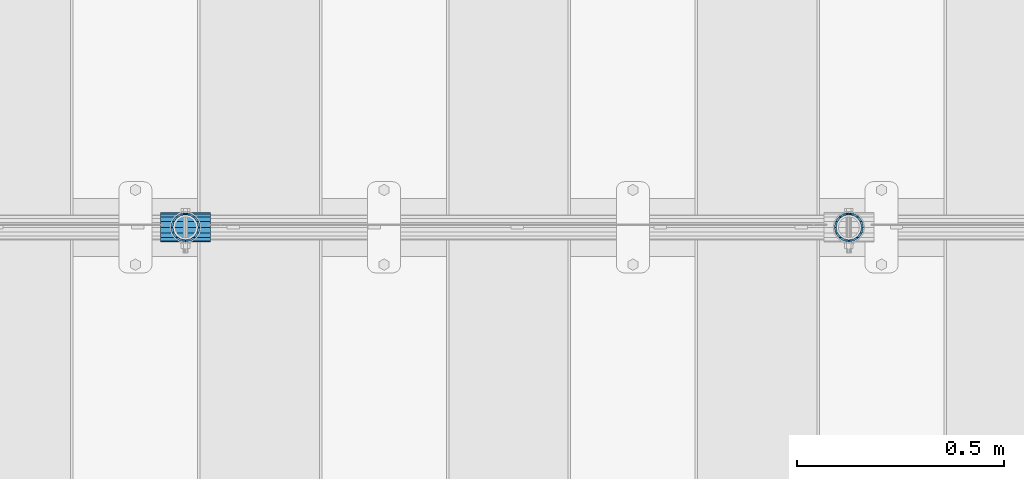
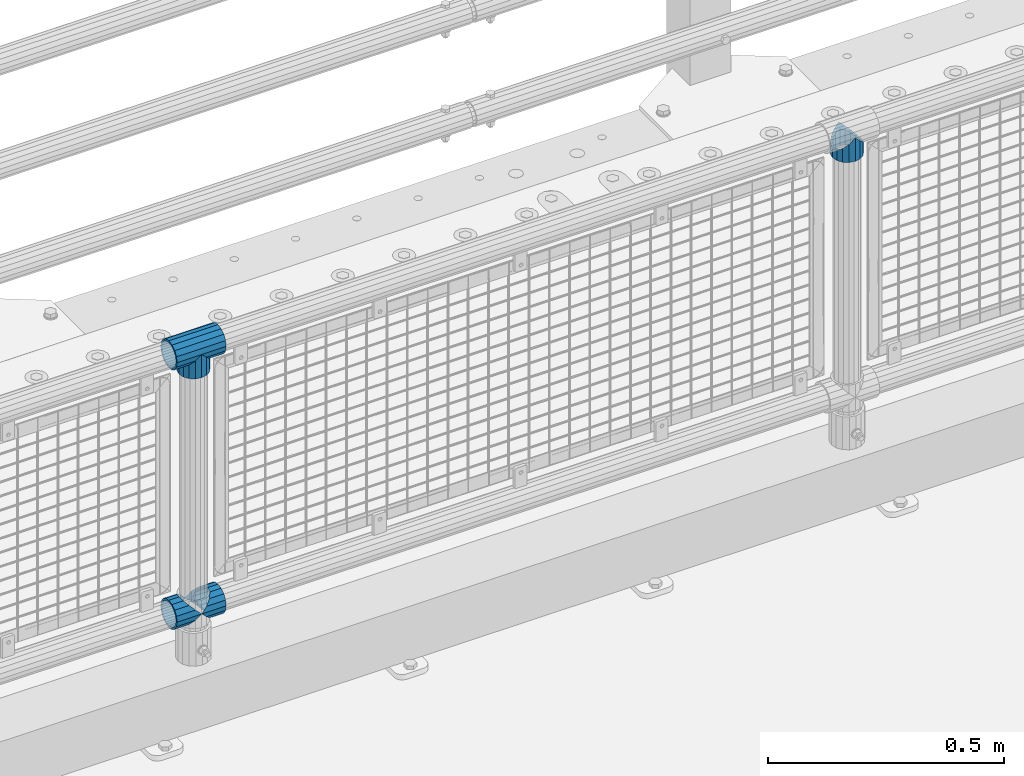
# One storey, part 122 of 208: 5 beams.
"""IFC2X3 building model written with IfcOpenShell, lengths in millimetres."""

from ifc_helpers import new_model, si_unit, frame, origin_with_axes, place, context, subcontext, project, spatial, faceted_brep, material, type_object, element, save


model = new_model("IFC2X3")

# Units and contexts
model_context = context("Model", 3, precision=1e-05, world=origin_with_axes())
body_context = subcontext(model_context, "Body", "Model", "MODEL_VIEW")
ifc_project = project(units=[si_unit("LENGTHUNIT", "METRE", prefix="MILLI"), si_unit("AREAUNIT", "SQUARE_METRE"), si_unit("VOLUMEUNIT", "CUBIC_METRE"), si_unit("MASSUNIT", "GRAM", prefix="KILO"), si_unit("TIMEUNIT", "SECOND"), si_unit("PLANEANGLEUNIT", "RADIAN"), si_unit("SOLIDANGLEUNIT", "STERADIAN"), si_unit("THERMODYNAMICTEMPERATUREUNIT", "DEGREE_CELSIUS"), si_unit("LUMINOUSINTENSITYUNIT", "LUMEN")], contexts=[model_context])

# Site, building, storey
site_placement = place(None, origin_with_axes())
site = spatial("IfcSite", under=ifc_project, at=site_placement, CompositionType="ELEMENT")
building_placement = place(site_placement, origin_with_axes())
building = spatial("IfcBuilding", under=site, at=building_placement, Name="Standard", CompositionType="ELEMENT")
storey_placement = place(building_placement, origin_with_axes())
storey = spatial("IfcBuildingStorey", under=building, at=storey_placement, Name="Undefined", CompositionType="ELEMENT", Elevation=0.0)

# Beams
ifc_material = material(Name="Misc_Undefined")
beam_type = type_object("IfcBeamType", PredefinedType="NOTDEFINED")
beam_1_placement = place(storey_placement, frame((-37029.0, 4664.5, 969.849999999999), z_axis=(0.0, 1.0, 0.0), x_axis=(0.0, 0.0, -1.0)))
element("IfcBeam", 1, at=beam_1_placement, inside=storey, type_object=beam_type, material=ifc_material, context=body_context, shape_type="Brep", body=[
    faceted_brep([(0.0, 0.0, 35.1499999999996), (13.4513226476338, 13.4513226476329, 32.4743655677721), (13.4513226476338, -13.4513226476329, 32.4743655677721), (32.4743655677739, -32.4743655677717, -13.4513226476329), (32.4743655677739, -26.8123795176766, -13.4513226476329), (27.1226768591077, -21.4606908090117, -21.4606908090118), (24.8548033587067, -16.3810424080039, -24.8548033587067), (24.8548033587067, -24.8548033587072, -24.8548033587067), (13.4513226476338, -13.4513226476329, -32.4743655677721), (13.4513226476338, 13.4513226476329, -32.4743655677721), (0.0, 0.0, -35.1499999999996), (20.0882031229849, -11.6144421722805, -28.0397438117179), (16.6306603983685, 0.0, -30.3500000000004), (20.0882031229849, 11.6144421722805, -28.0397438117179), (24.8548033587067, 16.3810424080023, -24.8548033587067), (24.8548033587067, 24.8548033587072, -24.8548033587067), (32.4743655677739, 26.8123795176755, -13.4513226476329), (32.4743655677739, 32.4743655677717, -13.4513226476329), (27.1226768591077, 21.4606908090117, -21.4606908090118), (35.1500000000015, 30.35, 0.0), (35.1500000000015, 35.15, 0.0), (32.8397438117172, 28.0397438117175, -11.6144421722802), (32.8397438117172, 28.0397438117175, 11.6144421722802), (32.4743655677739, 26.812379517676, 13.4513226476329), (32.4743655677739, 32.4743655677717, 13.4513226476329), (27.1226768591005, 21.4606908090117, 21.4606908090118), (24.8548033587067, 16.3810424080032, 24.8548033587067), (24.8548033587067, 24.8548033587072, 24.8548033587067), (20.0882031229921, 11.6144421722805, 28.0397438117179), (16.6306603983685, 0.0, 30.3500000000004), (20.0882031229921, -11.6144421722805, 28.0397438117179), (24.8548033587067, -16.3810424080039, 24.8548033587067), (24.8548033587067, -24.8548033587072, 24.8548033587067), (27.1226768591005, -21.4606908090117, 21.4606908090118), (32.4743655677739, -26.8123795176755, 13.4513226476329), (32.4743655677739, -32.4743655677717, 13.4513226476329), (32.8397438117172, -28.0397438117175, 11.6144421722802), (35.1500000000015, -30.35, 0.0), (35.1500000000015, -35.1499999999996, 0.0), (32.8397438117172, -28.0397438117175, -11.6144421722802), (60.1500000000015, -24.8548033587072, -24.8548033587067), (60.1500000000015, -32.4743655677717, -13.4513226476329), (60.1500000000015, -13.4513226476329, -32.4743655677721), (60.1500000000015, 0.0, -35.1499999999996), (60.1500000000015, 13.4513226476329, -32.4743655677721), (60.1500000000015, 24.8548033587072, -24.8548033587067), (60.1500000000015, 32.4743655677717, -13.4513226476329), (60.1500000000015, 35.15, 0.0), (60.1500000000015, 32.4743655677717, 13.4513226476329), (60.1500000000015, 24.8548033587072, 24.8548033587067), (60.1500000000015, 13.4513226476329, 32.4743655677721), (60.1500000000015, 0.0, 35.1499999999996), (60.1500000000015, -13.4513226476329, 32.4743655677721), (60.1500000000015, -24.8548033587072, 24.8548033587067), (60.1500000000015, -32.4743655677717, 13.4513226476329), (60.1500000000015, -35.15, 0.0), (60.1500000000015, -21.4606908090117, 21.4606908090118), (60.1500000000015, -11.6144421722805, 28.0397438117179), (60.1500000000015, 0.0, 30.3500000000004), (60.1500000000015, 11.6144421722805, 28.0397438117179), (60.1500000000015, 21.4606908090117, 21.4606908090118), (60.1500000000015, 28.0397438117175, 11.6144421722802), (60.1500000000015, 30.35, 0.0), (60.1500000000015, 28.0397438117175, -11.6144421722802), (60.1500000000015, 21.4606908090117, -21.4606908090118), (60.1500000000015, 11.6144421722805, -28.0397438117179), (60.1500000000015, 0.0, -30.3500000000004), (60.1500000000015, -11.6144421722805, -28.0397438117179), (60.1500000000015, -21.4606908090117, -21.4606908090118), (60.1500000000015, -28.0397438117175, -11.6144421722802), (60.1500000000015, -30.35, 0.0), (60.1500000000015, -28.0397438117175, 11.6144421722802)], [[[0, 1, 2]], [[3, 4, 5, 6, 7]], [[8, 9, 10]], [[7, 6, 11, 12, 13, 14, 15, 9, 8]], [[16, 17, 15, 14, 18]], [[19, 20, 17, 16, 21]], [[22, 23, 24, 20, 19]], [[25, 26, 27, 24, 23]], [[2, 1, 27, 26, 28, 29, 30, 31, 32]], [[32, 31, 33, 34, 35]], [[35, 34, 36, 37, 38]], [[38, 37, 39, 4, 3]], [[40, 41, 3, 7]], [[42, 40, 7, 8]], [[43, 42, 8, 10]], [[44, 43, 10, 9]], [[45, 44, 9, 15]], [[46, 45, 15, 17]], [[47, 46, 17, 20]], [[48, 47, 20, 24]], [[49, 48, 24, 27]], [[50, 49, 27, 1]], [[51, 50, 1, 0]], [[52, 51, 0, 2]], [[53, 52, 2, 32]], [[54, 53, 32, 35]], [[55, 54, 35, 38]], [[41, 55, 38, 3]], [[40, 42, 43, 44, 45, 46, 47, 48, 49, 50, 51, 52, 53, 54, 55, 41], [56, 57, 58, 59, 60, 61, 62, 63, 64, 65, 66, 67, 68, 69, 70, 71]], [[71, 70, 37, 36]], [[33, 56, 71, 36, 34]], [[30, 57, 56, 33, 31]], [[58, 57, 30, 29]], [[59, 58, 29, 28]], [[60, 59, 28, 26, 25]], [[61, 60, 25, 23, 22]], [[62, 61, 22, 19]], [[63, 62, 19, 21]], [[18, 64, 63, 21, 16]], [[13, 65, 64, 18, 14]], [[66, 65, 13, 12]], [[67, 66, 12, 11]], [[68, 67, 11, 6, 5]], [[69, 68, 5, 4, 39]], [[70, 69, 39, 37]]]),
])
beam_2_placement = place(storey_placement, frame((-38629.0, 4664.5, 969.849999999999), z_axis=(0.0, 1.0, 0.0), x_axis=(0.0, 0.0, -1.0)))
element("IfcBeam", 2, at=beam_2_placement, inside=storey, type_object=beam_type, material=ifc_material, context=body_context, shape_type="Brep", body=[
    faceted_brep([(0.0, 0.0, 35.1499999999996), (13.4513226476338, 13.4513226476329, 32.4743655677721), (13.4513226476338, -13.4513226476329, 32.4743655677721), (32.4743655677739, -32.4743655677717, -13.4513226476329), (32.4743655677739, -26.8123795176766, -13.4513226476329), (27.1226768591077, -21.4606908090117, -21.4606908090118), (24.8548033587067, -16.3810424080039, -24.8548033587067), (24.8548033587067, -24.8548033587072, -24.8548033587067), (13.4513226476338, -13.4513226476329, -32.4743655677721), (13.4513226476338, 13.4513226476329, -32.4743655677721), (0.0, 0.0, -35.1499999999996), (20.0882031229849, -11.6144421722805, -28.0397438117179), (16.6306603983685, 0.0, -30.3500000000004), (20.0882031229849, 11.6144421722805, -28.0397438117179), (24.8548033587067, 16.3810424080023, -24.8548033587067), (24.8548033587067, 24.8548033587072, -24.8548033587067), (32.4743655677739, 26.8123795176755, -13.4513226476329), (32.4743655677739, 32.4743655677717, -13.4513226476329), (27.1226768591077, 21.4606908090117, -21.4606908090118), (35.1500000000015, 30.35, 0.0), (35.1500000000015, 35.15, 0.0), (32.8397438117172, 28.0397438117175, -11.6144421722802), (32.8397438117172, 28.0397438117175, 11.6144421722802), (32.4743655677739, 26.812379517676, 13.4513226476329), (32.4743655677739, 32.4743655677717, 13.4513226476329), (27.1226768591005, 21.4606908090117, 21.4606908090118), (24.8548033587067, 16.3810424080032, 24.8548033587067), (24.8548033587067, 24.8548033587072, 24.8548033587067), (20.0882031229921, 11.6144421722805, 28.0397438117179), (16.6306603983685, 0.0, 30.3500000000004), (20.0882031229921, -11.6144421722805, 28.0397438117179), (24.8548033587067, -16.3810424080039, 24.8548033587067), (24.8548033587067, -24.8548033587072, 24.8548033587067), (27.1226768591005, -21.4606908090117, 21.4606908090118), (32.4743655677739, -26.8123795176755, 13.4513226476329), (32.4743655677739, -32.4743655677717, 13.4513226476329), (32.8397438117172, -28.0397438117175, 11.6144421722802), (35.1500000000015, -30.35, 0.0), (35.1500000000015, -35.1499999999996, 0.0), (32.8397438117172, -28.0397438117175, -11.6144421722802), (60.1500000000015, -24.8548033587072, -24.8548033587067), (60.1500000000015, -32.4743655677717, -13.4513226476329), (60.1500000000015, -13.4513226476329, -32.4743655677721), (60.1500000000015, 0.0, -35.1499999999996), (60.1500000000015, 13.4513226476329, -32.4743655677721), (60.1500000000015, 24.8548033587072, -24.8548033587067), (60.1500000000015, 32.4743655677717, -13.4513226476329), (60.1500000000015, 35.15, 0.0), (60.1500000000015, 32.4743655677717, 13.4513226476329), (60.1500000000015, 24.8548033587072, 24.8548033587067), (60.1500000000015, 13.4513226476329, 32.4743655677721), (60.1500000000015, 0.0, 35.1499999999996), (60.1500000000015, -13.4513226476329, 32.4743655677721), (60.1500000000015, -24.8548033587072, 24.8548033587067), (60.1500000000015, -32.4743655677717, 13.4513226476329), (60.1500000000015, -35.15, 0.0), (60.1500000000015, -21.4606908090117, 21.4606908090118), (60.1500000000015, -11.6144421722805, 28.0397438117179), (60.1500000000015, 0.0, 30.3500000000004), (60.1500000000015, 11.6144421722805, 28.0397438117179), (60.1500000000015, 21.4606908090117, 21.4606908090118), (60.1500000000015, 28.0397438117175, 11.6144421722802), (60.1500000000015, 30.35, 0.0), (60.1500000000015, 28.0397438117175, -11.6144421722802), (60.1500000000015, 21.4606908090117, -21.4606908090118), (60.1500000000015, 11.6144421722805, -28.0397438117179), (60.1500000000015, 0.0, -30.3500000000004), (60.1500000000015, -11.6144421722805, -28.0397438117179), (60.1500000000015, -21.4606908090117, -21.4606908090118), (60.1500000000015, -28.0397438117175, -11.6144421722802), (60.1500000000015, -30.35, 0.0), (60.1500000000015, -28.0397438117175, 11.6144421722802)], [[[0, 1, 2]], [[3, 4, 5, 6, 7]], [[8, 9, 10]], [[7, 6, 11, 12, 13, 14, 15, 9, 8]], [[16, 17, 15, 14, 18]], [[19, 20, 17, 16, 21]], [[22, 23, 24, 20, 19]], [[25, 26, 27, 24, 23]], [[2, 1, 27, 26, 28, 29, 30, 31, 32]], [[32, 31, 33, 34, 35]], [[35, 34, 36, 37, 38]], [[38, 37, 39, 4, 3]], [[40, 41, 3, 7]], [[42, 40, 7, 8]], [[43, 42, 8, 10]], [[44, 43, 10, 9]], [[45, 44, 9, 15]], [[46, 45, 15, 17]], [[47, 46, 17, 20]], [[48, 47, 20, 24]], [[49, 48, 24, 27]], [[50, 49, 27, 1]], [[51, 50, 1, 0]], [[52, 51, 0, 2]], [[53, 52, 2, 32]], [[54, 53, 32, 35]], [[55, 54, 35, 38]], [[41, 55, 38, 3]], [[40, 42, 43, 44, 45, 46, 47, 48, 49, 50, 51, 52, 53, 54, 55, 41], [56, 57, 58, 59, 60, 61, 62, 63, 64, 65, 66, 67, 68, 69, 70, 71]], [[71, 70, 37, 36]], [[33, 56, 71, 36, 34]], [[30, 57, 56, 33, 31]], [[58, 57, 30, 29]], [[59, 58, 29, 28]], [[60, 59, 28, 26, 25]], [[61, 60, 25, 23, 22]], [[62, 61, 22, 19]], [[63, 62, 19, 21]], [[18, 64, 63, 21, 16]], [[13, 65, 64, 18, 14]], [[66, 65, 13, 12]], [[67, 66, 12, 11]], [[68, 67, 11, 6, 5]], [[69, 68, 5, 4, 39]], [[70, 69, 39, 37]]]),
])
beam_3_placement = place(storey_placement, frame((-38689.15, 4664.5, 969.849999999999), z_axis=(0.0, 0.0, 1.0), x_axis=(1.0, 0.0, 0.0)))
element("IfcBeam", 3, at=beam_3_placement, inside=storey, type_object=beam_type, material=ifc_material, context=body_context, shape_type="Brep", body=[
    faceted_brep([(88.1897438117194, -11.6144421722802, -28.0397438117176), (88.1897438117194, -11.6144421722802, -32.8397438117178), (86.9623795176776, -13.4513226476329, -32.4743655677718), (81.6106908090114, -21.4606908090118, -27.1226768591068), (81.6106908090114, -21.4606908090118, -21.4606908090117), (76.531042407998, -24.8548033587067, -24.8548033587072), (71.7644421722835, -28.0397438117179, -20.0882031229861), (71.7644421722835, -28.0397438117179, -11.6144421722805), (60.1500000000015, -30.3500000000004, -16.6306603983687), (60.1500000000015, -30.35, 0.0), (48.5355578277195, -28.0397438117179, -20.0882031229861), (48.5355578277195, -28.0397438117179, -11.6144421722805), (43.7689575919976, -24.8548033587067, -24.8548033587072), (38.6893091909915, -21.4606908090118, -27.1226768591068), (38.6893091909915, -21.4606908090118, -21.4606908090117), (33.3376204823217, -13.4513226476329, -32.4743655677718), (32.1102561882835, -11.6144421722802, -32.8397438117178), (32.1102561882835, -11.6144421722802, -28.0397438117176), (29.8000000000029, 0.0, -35.15), (29.8000000000029, 0.0, -30.35), (32.1102561882835, 11.6144421722802, -32.8397438117175), (32.1102561882835, 11.6144421722802, -28.0397438117176), (33.3376204823217, 13.4513226476329, -32.4743655677718), (38.6893091909915, 21.4606908090118, -27.122676859108), (38.6893091909915, 21.4606908090118, -21.4606908090117), (43.7689575920012, 24.8548033587067, -24.8548033587072), (48.5355578277195, 28.0397438117179, -20.0882031229838), (48.5355578277195, 28.0397438117179, -11.6144421722805), (60.1500000000015, 30.3500000000004, -16.6306603983671), (60.1500000000015, 30.35, 0.0), (71.7644421722835, 28.0397438117179, -20.0882031229838), (71.7644421722835, 28.0397438117179, -11.6144421722805), (76.5310424080089, 24.8548033587067, -24.8548033587072), (81.6106908090114, 21.4606908090118, -27.122676859108), (81.6106908090114, 21.4606908090118, -21.4606908090117), (86.9623795176776, 13.4513226476329, -32.4743655677718), (88.1897438117194, 11.6144421722802, -32.8397438117175), (88.1897438117194, 11.6144421722802, -28.0397438117176), (90.5, 0.0, -35.15), (90.5, 0.0, -30.35), (0.0, -21.4606908090118, -21.4606908090136), (0.0, -28.0397438117179, -11.6144421722784), (0.0, -11.6144421722802, -28.0397438117143), (0.0, 0.0, -30.3499999999985), (0.0, 11.6144421722802, -28.0397438117143), (0.0, 21.4606908090118, -21.4606908090136), (0.0, 28.0397438117179, -11.6144421722784), (0.0, 30.3500000000004, 0.0), (0.0, 32.4743655677721, -13.4513226476338), (0.0, 35.1499999999996, 0.0), (120.299999999999, 35.1499999999996, 0.0), (120.299999999999, 32.4743655677721, -13.4513226476329), (0.0, 32.4743655677721, 13.4513226476338), (120.299999999999, 32.4743655677721, 13.4513226476329), (0.0, 24.8548033587067, 24.8548033587067), (120.299999999999, 24.8548033587067, 24.8548033587072), (0.0, 13.4513226476329, 32.4743655677739), (120.299999999999, 13.4513226476329, 32.4743655677718), (0.0, 0.0, 35.1499999999996), (120.299999999999, 0.0, 35.15), (0.0, -13.4513226476329, 32.4743655677739), (120.299999999999, -13.4513226476329, 32.4743655677718), (0.0, -24.8548033587067, 24.8548033587067), (120.299999999999, -24.8548033587067, 24.8548033587072), (0.0, -32.4743655677721, 13.4513226476338), (120.299999999999, -32.4743655677721, 13.4513226476329), (0.0, -35.1499999999996, 0.0), (120.299999999999, -35.1499999999996, 0.0), (0.0, -32.4743655677721, -13.4513226476338), (120.299999999999, -32.4743655677721, -13.4513226476329), (0.0, 24.8548033587067, -24.8548033587067), (0.0, 13.4513226476329, -32.4743655677739), (0.0, 0.0, -35.1499999999996), (0.0, -13.4513226476329, -32.4743655677739), (0.0, -24.8548033587067, -24.8548033587067), (0.0, 28.0397438117179, 11.6144421722784), (0.0, 21.4606908090118, 21.4606908090136), (0.0, 11.6144421722802, 28.0397438117143), (0.0, 0.0, 30.3499999999985), (0.0, -11.6144421722802, 28.0397438117143), (0.0, -21.4606908090118, 21.4606908090136), (0.0, -28.0397438117179, 11.6144421722784), (0.0, -30.3500000000004, 0.0), (120.299999999999, -30.3500000000004, 0.0), (120.299999999999, -28.0397438117179, -11.6144421722805), (120.299999999999, -21.4606908090118, -21.4606908090117), (120.299999999999, -11.6144421722802, -28.0397438117176), (120.299999999999, 0.0, -30.35), (120.299999999999, 21.4606908090118, -21.4606908090117), (120.299999999999, 28.0397438117179, -11.6144421722805), (120.299999999999, 11.6144421722802, -28.0397438117176), (120.299999999999, 30.3500000000004, 0.0), (120.299999999999, 28.0397438117179, 11.6144421722805), (120.299999999999, 21.4606908090118, 21.4606908090117), (120.299999999999, 11.6144421722802, 28.0397438117176), (120.299999999999, 0.0, 30.35), (120.299999999999, -11.6144421722802, 28.0397438117176), (120.299999999999, -21.4606908090118, 21.4606908090117), (120.299999999999, -28.0397438117179, 11.6144421722805), (120.299999999999, -24.8548033587067, -24.8548033587072), (120.299999999999, -13.4513226476329, -32.4743655677718), (120.299999999999, 0.0, -35.15), (120.299999999999, 13.4513226476329, -32.4743655677718), (120.299999999999, 24.8548033587067, -24.8548033587072)], [[[0, 1, 2, 3, 4]], [[4, 3, 5, 6, 7]], [[7, 6, 8, 9]], [[9, 8, 10, 11]], [[11, 10, 12, 13, 14]], [[14, 13, 15, 16, 17]], [[17, 16, 18, 19]], [[19, 18, 20, 21]], [[21, 20, 22, 23, 24]], [[24, 23, 25, 26, 27]], [[27, 26, 28, 29]], [[29, 28, 30, 31]], [[31, 30, 32, 33, 34]], [[34, 33, 35, 36, 37]], [[37, 36, 38, 39]], [[39, 38, 1, 0]], [[40, 41, 11, 14]], [[42, 40, 14, 17]], [[43, 42, 17, 19]], [[44, 43, 19, 21]], [[45, 44, 21, 24]], [[46, 45, 24, 27]], [[47, 46, 27, 29]], [[48, 49, 50, 51]], [[49, 52, 53, 50]], [[52, 54, 55, 53]], [[54, 56, 57, 55]], [[56, 58, 59, 57]], [[58, 60, 61, 59]], [[60, 62, 63, 61]], [[62, 64, 65, 63]], [[64, 66, 67, 65]], [[66, 68, 69, 67]], [[64, 62, 60, 58, 56, 54, 52, 49, 48, 70, 71, 72, 73, 74, 68, 66], [41, 40, 42, 43, 44, 45, 46, 47, 75, 76, 77, 78, 79, 80, 81, 82]], [[41, 82, 9, 11]], [[83, 84, 7, 9]], [[84, 85, 4, 7]], [[85, 86, 0, 4]], [[86, 87, 39, 0]], [[88, 89, 31, 34]], [[90, 88, 34, 37]], [[87, 90, 37, 39]], [[89, 91, 29, 31]], [[75, 47, 29, 91, 92]], [[76, 75, 92, 93]], [[77, 76, 93, 94]], [[78, 77, 94, 95]], [[79, 78, 95, 96]], [[80, 79, 96, 97]], [[81, 80, 97, 98]], [[9, 82, 81, 98, 83]], [[99, 100, 101, 102, 103, 51, 50, 53, 55, 57, 59, 61, 63, 65, 67, 69], [97, 96, 95, 94, 93, 92, 91, 89, 88, 90, 87, 86, 85, 84, 83, 98]], [[35, 102, 101, 38, 36]], [[32, 103, 102, 35, 33]], [[28, 26, 25, 70, 48, 51, 103, 32, 30]], [[22, 71, 70, 25, 23]], [[18, 72, 71, 22, 20]], [[73, 72, 18, 16, 15]], [[74, 73, 15, 13, 12]], [[99, 69, 68, 74, 12, 10, 8, 6, 5]], [[100, 99, 5, 3, 2]], [[101, 100, 2, 1, 38]]]),
])
beam_4_placement = place(storey_placement, frame((-38689.15, 4664.5, 298.17), z_axis=(0.0, 1.0, 0.0), x_axis=(1.0, 0.0, 0.0)))
element("IfcBeam", 4, at=beam_4_placement, inside=storey, type_object=beam_type, material=ifc_material, context=body_context, shape_type="Brep", body=[
    faceted_brep([(60.1500000000015, 0.0, -35.1499999999996), (46.6986773523677, 13.4513226476329, -32.4743655677721), (46.6986773523677, -13.4513226476329, -32.4743655677721), (33.0273231408937, 21.4606908090117, 21.4606908090118), (27.6756344322275, 26.812379517676, 13.4513226476329), (27.6756344322275, 32.4743655677717, 13.4513226476329), (35.2951966412948, 24.8548033587072, 24.8548033587067), (35.2951966412948, 16.3810424080032, 24.8548033587067), (27.3102561882915, 28.0397438117175, 11.6144421722802), (25.0, 30.35, 0.0), (25.0, 35.15, 0.0), (27.6756344322275, 26.8123795176755, -13.4513226476329), (27.6756344322275, 32.4743655677717, -13.4513226476329), (27.3102561882843, 28.0397438117175, -11.6144421722802), (35.2951966412948, 16.3810424080024, -24.8548033587067), (35.2951966412948, 24.8548033587072, -24.8548033587067), (33.0273231408864, 21.4606908090117, -21.4606908090118), (40.0617968770239, 11.6144421722805, -28.0397438117179), (43.5193396016402, 0.0, -30.3500000000004), (40.0617968770239, -11.6144421722805, -28.0397438117179), (35.2951966412948, -16.3810424080032, -24.8548033587067), (35.2951966412948, -24.8548033587072, -24.8548033587067), (33.0273231408864, -21.4606908090117, -21.4606908090118), (27.6756344322275, -26.812379517676, -13.4513226476329), (27.6756344322275, -32.4743655677717, -13.4513226476329), (27.3102561882843, -28.0397438117175, -11.6144421722802), (25.0, -30.35, 0.0), (25.0, -35.15, 0.0), (27.3102561882915, -28.0397438117175, 11.6144421722802), (27.6756344322275, -26.8123795176755, 13.4513226476329), (27.6756344322275, -32.4743655677717, 13.4513226476329), (33.0273231408937, -21.4606908090117, 21.4606908090118), (35.2951966412948, -16.3810424080032, 24.8548033587067), (35.2951966412948, -24.8548033587072, 24.8548033587067), (60.1500000000015, 0.0, 35.1499999999996), (46.6986773523677, -13.4513226476329, 32.4743655677721), (46.6986773523677, 13.4513226476329, 32.4743655677721), (40.0617968770093, -11.6144421722805, 28.0397438117179), (43.519339601633, 0.0, 30.3500000000004), (40.0617968770093, 11.6144421722805, 28.0397438117179), (0.0, -32.4743655677721, -13.4513226476338), (0.0, -24.8548033587067, -24.8548033587067), (0.0, -13.4513226476329, -32.4743655677739), (0.0, 0.0, -35.1499999999996), (0.0, 13.4513226476329, -32.4743655677739), (0.0, 24.8548033587067, -24.8548033587067), (0.0, 32.4743655677721, -13.4513226476338), (0.0, 35.1499999999996, 0.0), (0.0, 32.4743655677721, 13.4513226476338), (0.0, 24.8548033587067, 24.8548033587067), (0.0, 13.4513226476329, 32.4743655677739), (0.0, 0.0, 35.1499999999996), (0.0, -32.4743655677721, 13.4513226476338), (0.0, -35.1499999999996, 0.0), (0.0, -24.8548033587067, 24.8548033587067), (0.0, -13.4513226476329, 32.4743655677739), (0.0, -28.0397438117179, -11.6144421722784), (0.0, -21.4606908090118, -21.4606908090136), (0.0, -11.6144421722802, -28.0397438117143), (0.0, 0.0, -30.3499999999985), (0.0, 11.6144421722802, -28.0397438117143), (0.0, 21.4606908090118, -21.4606908090136), (0.0, 28.0397438117179, -11.6144421722784), (0.0, 30.3500000000004, 0.0), (0.0, 28.0397438117179, 11.6144421722784), (0.0, 21.4606908090118, 21.4606908090136), (0.0, 11.6144421722802, 28.0397438117143), (0.0, 0.0, 30.3499999999985), (0.0, -11.6144421722802, 28.0397438117143), (0.0, -21.4606908090118, 21.4606908090136), (0.0, -28.0397438117179, 11.6144421722784), (0.0, -30.3500000000004, 0.0)], [[[0, 1, 2]], [[3, 4, 5, 6, 7]], [[8, 9, 10, 5, 4]], [[11, 12, 10, 9, 13]], [[14, 15, 12, 11, 16]], [[2, 1, 15, 14, 17, 18, 19, 20, 21]], [[21, 20, 22, 23, 24]], [[24, 23, 25, 26, 27]], [[27, 26, 28, 29, 30]], [[30, 29, 31, 32, 33]], [[34, 35, 36]], [[33, 32, 37, 38, 39, 7, 6, 36, 35]], [[40, 41, 21, 24]], [[41, 42, 2, 21]], [[42, 43, 0, 2]], [[43, 44, 1, 0]], [[44, 45, 15, 1]], [[45, 46, 12, 15]], [[46, 47, 10, 12]], [[47, 48, 5, 10]], [[48, 49, 6, 5]], [[49, 50, 36, 6]], [[50, 51, 34, 36]], [[52, 53, 27, 30]], [[54, 52, 30, 33]], [[55, 54, 33, 35]], [[51, 55, 35, 34]], [[53, 40, 24, 27]], [[52, 54, 55, 51, 50, 49, 48, 47, 46, 45, 44, 43, 42, 41, 40, 53], [56, 57, 58, 59, 60, 61, 62, 63, 64, 65, 66, 67, 68, 69, 70, 71]], [[68, 67, 38, 37]], [[31, 69, 68, 37, 32]], [[28, 70, 69, 31, 29]], [[71, 70, 28, 26]], [[56, 71, 26, 25]], [[57, 56, 25, 23, 22]], [[58, 57, 22, 20, 19]], [[59, 58, 19, 18]], [[60, 59, 18, 17]], [[16, 61, 60, 17, 14]], [[13, 62, 61, 16, 11]], [[63, 62, 13, 9]], [[64, 63, 9, 8]], [[65, 64, 8, 4, 3]], [[66, 65, 3, 7, 39]], [[67, 66, 39, 38]]]),
])
beam_5_placement = place(storey_placement, frame((-38629.0, 4664.5, 298.17), z_axis=(0.0, 1.0, 0.0), x_axis=(1.0, 0.0, 0.0)))
element("IfcBeam", 5, at=beam_5_placement, inside=storey, type_object=beam_type, material=ifc_material, context=body_context, shape_type="Brep", body=[
    faceted_brep([(0.0, 0.0, 35.1499999999996), (13.4513226476338, 13.4513226476329, 32.4743655677721), (13.4513226476338, -13.4513226476329, 32.4743655677721), (32.4743655677739, -32.4743655677717, -13.4513226476329), (32.4743655677739, -26.8123795176766, -13.4513226476329), (27.1226768591077, -21.4606908090117, -21.4606908090118), (24.8548033587067, -16.3810424080039, -24.8548033587067), (24.8548033587067, -24.8548033587072, -24.8548033587067), (13.4513226476338, -13.4513226476329, -32.4743655677721), (13.4513226476338, 13.4513226476329, -32.4743655677721), (0.0, 0.0, -35.1499999999996), (20.0882031229849, -11.6144421722805, -28.0397438117179), (16.6306603983685, 0.0, -30.3500000000004), (20.0882031229849, 11.6144421722805, -28.0397438117179), (24.8548033587067, 16.3810424080023, -24.8548033587067), (24.8548033587067, 24.8548033587072, -24.8548033587067), (32.4743655677739, 26.8123795176755, -13.4513226476329), (32.4743655677739, 32.4743655677717, -13.4513226476329), (27.1226768591077, 21.4606908090117, -21.4606908090118), (35.1500000000015, 30.35, 0.0), (35.1500000000015, 35.15, 0.0), (32.8397438117172, 28.0397438117175, -11.6144421722802), (32.8397438117172, 28.0397438117175, 11.6144421722802), (32.4743655677739, 26.812379517676, 13.4513226476329), (32.4743655677739, 32.4743655677717, 13.4513226476329), (27.1226768591005, 21.4606908090117, 21.4606908090118), (24.8548033587067, 16.3810424080032, 24.8548033587067), (24.8548033587067, 24.8548033587072, 24.8548033587067), (20.0882031229921, 11.6144421722805, 28.0397438117179), (16.6306603983685, 0.0, 30.3500000000004), (20.0882031229921, -11.6144421722805, 28.0397438117179), (24.8548033587067, -16.3810424080039, 24.8548033587067), (24.8548033587067, -24.8548033587072, 24.8548033587067), (27.1226768591005, -21.4606908090117, 21.4606908090118), (32.4743655677739, -26.8123795176755, 13.4513226476329), (32.4743655677739, -32.4743655677717, 13.4513226476329), (32.8397438117172, -28.0397438117175, 11.6144421722802), (35.1500000000015, -30.35, 0.0), (35.1500000000015, -35.1499999999996, 0.0), (32.8397438117172, -28.0397438117175, -11.6144421722802), (60.1500000000015, -24.8548033587072, -24.8548033587067), (60.1500000000015, -32.4743655677717, -13.4513226476329), (60.1500000000015, -13.4513226476329, -32.4743655677721), (60.1500000000015, 0.0, -35.1499999999996), (60.1500000000015, 13.4513226476329, -32.4743655677721), (60.1500000000015, 24.8548033587072, -24.8548033587067), (60.1500000000015, 32.4743655677717, -13.4513226476329), (60.1500000000015, 35.15, 0.0), (60.1500000000015, 32.4743655677717, 13.4513226476329), (60.1500000000015, 24.8548033587072, 24.8548033587067), (60.1500000000015, 13.4513226476329, 32.4743655677721), (60.1500000000015, 0.0, 35.1499999999996), (60.1500000000015, -13.4513226476329, 32.4743655677721), (60.1500000000015, -24.8548033587072, 24.8548033587067), (60.1500000000015, -32.4743655677717, 13.4513226476329), (60.1500000000015, -35.15, 0.0), (60.1500000000015, -21.4606908090117, 21.4606908090118), (60.1500000000015, -11.6144421722805, 28.0397438117179), (60.1500000000015, 0.0, 30.3500000000004), (60.1500000000015, 11.6144421722805, 28.0397438117179), (60.1500000000015, 21.4606908090117, 21.4606908090118), (60.1500000000015, 28.0397438117175, 11.6144421722802), (60.1500000000015, 30.35, 0.0), (60.1500000000015, 28.0397438117175, -11.6144421722802), (60.1500000000015, 21.4606908090117, -21.4606908090118), (60.1500000000015, 11.6144421722805, -28.0397438117179), (60.1500000000015, 0.0, -30.3500000000004), (60.1500000000015, -11.6144421722805, -28.0397438117179), (60.1500000000015, -21.4606908090117, -21.4606908090118), (60.1500000000015, -28.0397438117175, -11.6144421722802), (60.1500000000015, -30.35, 0.0), (60.1500000000015, -28.0397438117175, 11.6144421722802)], [[[0, 1, 2]], [[3, 4, 5, 6, 7]], [[8, 9, 10]], [[7, 6, 11, 12, 13, 14, 15, 9, 8]], [[16, 17, 15, 14, 18]], [[19, 20, 17, 16, 21]], [[22, 23, 24, 20, 19]], [[25, 26, 27, 24, 23]], [[2, 1, 27, 26, 28, 29, 30, 31, 32]], [[32, 31, 33, 34, 35]], [[35, 34, 36, 37, 38]], [[38, 37, 39, 4, 3]], [[40, 41, 3, 7]], [[42, 40, 7, 8]], [[43, 42, 8, 10]], [[44, 43, 10, 9]], [[45, 44, 9, 15]], [[46, 45, 15, 17]], [[47, 46, 17, 20]], [[48, 47, 20, 24]], [[49, 48, 24, 27]], [[50, 49, 27, 1]], [[51, 50, 1, 0]], [[52, 51, 0, 2]], [[53, 52, 2, 32]], [[54, 53, 32, 35]], [[55, 54, 35, 38]], [[41, 55, 38, 3]], [[40, 42, 43, 44, 45, 46, 47, 48, 49, 50, 51, 52, 53, 54, 55, 41], [56, 57, 58, 59, 60, 61, 62, 63, 64, 65, 66, 67, 68, 69, 70, 71]], [[71, 70, 37, 36]], [[33, 56, 71, 36, 34]], [[30, 57, 56, 33, 31]], [[58, 57, 30, 29]], [[59, 58, 29, 28]], [[60, 59, 28, 26, 25]], [[61, 60, 25, 23, 22]], [[62, 61, 22, 19]], [[63, 62, 19, 21]], [[18, 64, 63, 21, 16]], [[13, 65, 64, 18, 14]], [[66, 65, 13, 12]], [[67, 66, 12, 11]], [[68, 67, 11, 6, 5]], [[69, 68, 5, 4, 39]], [[70, 69, 39, 37]]]),
])

save(model, "model.ifc")
